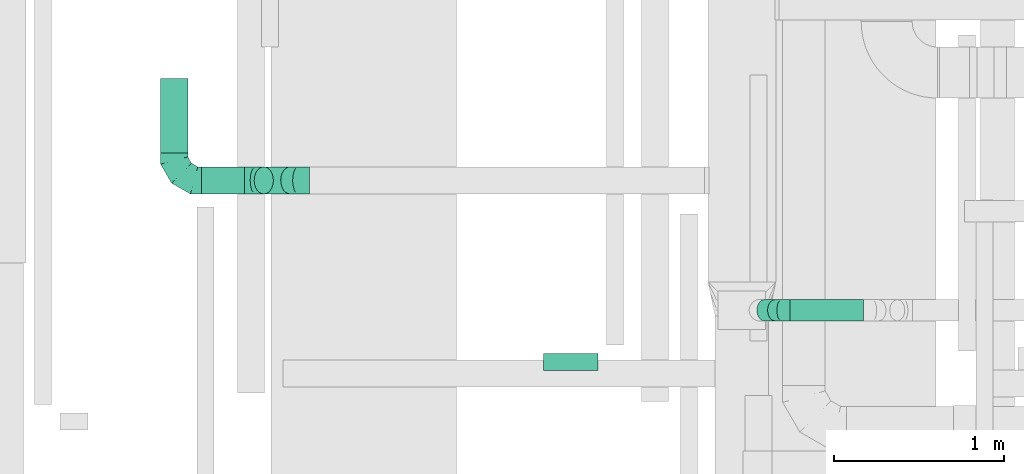
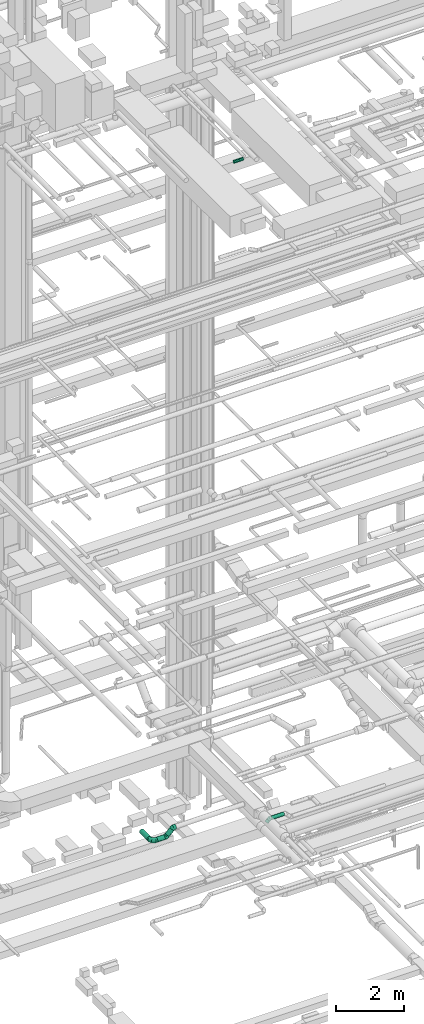
# One storey, part 120 of 337: 6 flow segments, 4 flow fittings.
"""IFC2X3 building model written with IfcOpenShell, lengths in millimetres."""

from ifc_helpers import new_model, entity, si_unit, converted_unit, derived_unit, direction, frame, origin, origin_2d_with_axis, place, context, subcontext, project, spatial, circle, extrude, faceted_brep, source, transform, mapped, material, type_object, type_shapes, element, save


model = new_model("IFC2X3")

# Units and contexts
model_context = context("Model", 3, precision=0.01, world=origin(), true_north=direction((6.12303176911189e-17, 1.0)))
body_context = subcontext(model_context, "Body", "Model", "MODEL_VIEW")
ifc_project = project(units=[si_unit("LENGTHUNIT", "METRE", prefix="MILLI"), si_unit("AREAUNIT", "SQUARE_METRE"), si_unit("VOLUMEUNIT", "CUBIC_METRE"), converted_unit("PLANEANGLEUNIT", "DEGREE", entity("IfcRatioMeasure", 0.0174532925199433), si_unit("PLANEANGLEUNIT", "RADIAN"), dimensions=[0, 0, 0, 0, 0, 0, 0]), si_unit("MASSUNIT", "GRAM", prefix="KILO"), derived_unit("MASSDENSITYUNIT", [(si_unit("MASSUNIT", "GRAM", prefix="KILO"), 1), (si_unit("LENGTHUNIT", "METRE"), -3)]), derived_unit("MOMENTOFINERTIAUNIT", [(si_unit("LENGTHUNIT", "METRE"), 4)]), si_unit("TIMEUNIT", "SECOND"), si_unit("FREQUENCYUNIT", "HERTZ"), si_unit("THERMODYNAMICTEMPERATUREUNIT", "DEGREE_CELSIUS"), derived_unit("THERMALTRANSMITTANCEUNIT", [(si_unit("MASSUNIT", "GRAM", prefix="KILO"), 1), (si_unit("THERMODYNAMICTEMPERATUREUNIT", "KELVIN"), -1), (si_unit("TIMEUNIT", "SECOND"), -3)]), derived_unit("VOLUMETRICFLOWRATEUNIT", [(si_unit("LENGTHUNIT", "METRE"), 3), (si_unit("TIMEUNIT", "SECOND"), -1)]), derived_unit("MASSFLOWRATEUNIT", [(si_unit("MASSUNIT", "GRAM", prefix="KILO"), 1), (si_unit("TIMEUNIT", "SECOND"), -1)]), derived_unit("ROTATIONALFREQUENCYUNIT", [(si_unit("TIMEUNIT", "SECOND"), -1)]), si_unit("ELECTRICCURRENTUNIT", "AMPERE"), si_unit("ELECTRICVOLTAGEUNIT", "VOLT"), si_unit("POWERUNIT", "WATT"), si_unit("FORCEUNIT", "NEWTON", prefix="KILO"), si_unit("ILLUMINANCEUNIT", "LUX"), si_unit("LUMINOUSFLUXUNIT", "LUMEN"), si_unit("LUMINOUSINTENSITYUNIT", "CANDELA"), derived_unit("USERDEFINED", [(si_unit("MASSUNIT", "GRAM", prefix="KILO"), -1), (si_unit("LENGTHUNIT", "METRE"), -2), (si_unit("TIMEUNIT", "SECOND"), 3), (si_unit("LUMINOUSFLUXUNIT", "LUMEN"), 1)]), derived_unit("LINEARVELOCITYUNIT", [(si_unit("LENGTHUNIT", "METRE"), 1), (si_unit("TIMEUNIT", "SECOND"), -1)]), si_unit("PRESSUREUNIT", "PASCAL"), derived_unit("USERDEFINED", [(si_unit("LENGTHUNIT", "METRE"), -2), (si_unit("MASSUNIT", "GRAM", prefix="KILO"), 1), (si_unit("TIMEUNIT", "SECOND"), -2)]), derived_unit("LINEARFORCEUNIT", [(si_unit("MASSUNIT", "GRAM", prefix="KILO"), 1), (si_unit("LENGTHUNIT", "METRE"), 1), (si_unit("TIMEUNIT", "SECOND"), -2), (si_unit("LENGTHUNIT", "METRE"), -1)]), derived_unit("PLANARFORCEUNIT", [(si_unit("MASSUNIT", "GRAM", prefix="KILO"), 1), (si_unit("LENGTHUNIT", "METRE"), 1), (si_unit("TIMEUNIT", "SECOND"), -2), (si_unit("LENGTHUNIT", "METRE"), -2)])], contexts=[model_context])

# Site, building, storey
site_placement = place(None, origin())
site = spatial("IfcSite", under=ifc_project, at=site_placement, CompositionType="ELEMENT")
building_placement = place(site_placement, origin())
building = spatial("IfcBuilding", under=site, at=building_placement, CompositionType="ELEMENT")
storey_placement = place(building_placement, origin())
storey = spatial("IfcBuildingStorey", under=building, at=storey_placement, CompositionType="ELEMENT", Elevation=0.0)

# Flow segments
duct_segment_type = type_object("IfcDuctSegmentType", PredefinedType="NOTDEFINED")
flow_segment_1_placement = place(storey_placement, frame((26754.46, 5894.29, 3188.7)))
element("IfcFlowSegment", 1, at=flow_segment_1_placement, inside=storey, type_object=duct_segment_type, context=body_context, shape_type="SweptSolid", body=[
    extrude(circle(Radius=80.0, at=origin_2d_with_axis()), frame((58.16, 81.6, 58.16), z_axis=(0.707106781186507, 0.0, 0.707106781186588), x_axis=(0.0, 1.0, 0.0)), (0.0, 0.0, 1.0), 221.005050633868),
])
flow_segment_2_placement = place(storey_placement, frame((26445.34, 5894.29, 3118.4)))
element("IfcFlowSegment", 2, at=flow_segment_2_placement, inside=storey, type_object=duct_segment_type, context=body_context, shape_type="SweptSolid", body=[
    extrude(circle(Radius=80.0, at=origin_2d_with_axis()), frame((0.0, 81.6, 81.6), z_axis=(1.0, 0.0, 0.0), x_axis=(0.0, 1.0, 0.0)), (0.0, 0.0, 1.0), 254.142135623723),
])
flow_segment_3_placement = place(storey_placement, frame((26203.75, 6135.89, 3118.4)))
element("IfcFlowSegment", 3, at=flow_segment_3_placement, inside=storey, type_object=duct_segment_type, context=body_context, shape_type="SweptSolid", body=[
    extrude(circle(Radius=80.0, at=origin_2d_with_axis()), frame((81.6, 0.0, 81.6), z_axis=(0.0, 1.0, 0.0), x_axis=(1.0, 0.0, 0.0)), (0.0, 0.0, 1.0), 440.000000000006),
])
flow_segment_4_placement = place(storey_placement, frame((28458.42, 4854.91, 27548.4)))
element("IfcFlowSegment", 4, at=flow_segment_4_placement, inside=storey, type_object=duct_segment_type, context=body_context, shape_type="SweptSolid", body=[
    extrude(circle(Radius=50.0, at=origin_2d_with_axis()), frame((0.0, 51.6, 51.6), z_axis=(1.0, 0.0, 0.0), x_axis=(0.0, 1.0, 0.0)), (0.0, 0.0, 1.0), 320.000000000018),
])
flow_segment_5_placement = place(storey_placement, frame((29909.87, 5147.75, 3169.75)))
element("IfcFlowSegment", 5, at=flow_segment_5_placement, inside=storey, type_object=duct_segment_type, context=body_context, shape_type="SweptSolid", body=[
    extrude(circle(Radius=62.5, at=origin_2d_with_axis()), frame((0.0, 64.1, 64.1), z_axis=(1.0, 0.0, 0.0), x_axis=(0.0, 1.0, 0.0)), (0.0, 0.0, 1.0), 431.314672620889),
])
flow_segment_6_placement = place(storey_placement, frame((29712.8, 5147.75, 3088.56)))
element("IfcFlowSegment", 6, at=flow_segment_6_placement, inside=storey, type_object=duct_segment_type, context=body_context, shape_type="SweptSolid", body=[
    extrude(circle(Radius=62.5, at=origin_2d_with_axis()), frame((45.79, 64.1, 45.79), z_axis=(0.707106781186542, 0.0, 0.707106781186553), x_axis=(0.0, 1.0, 0.0)), (0.0, 0.0, 1.0), 88.9339828220641),
])

# Flow fittings
ifc_material = material()
duct_fitting_type_1 = type_object("IfcDuctFittingType", PredefinedType="NOTDEFINED", material=ifc_material)
shared_shape_1 = source(origin(), body_context, "Body", "Brep", [
    faceted_brep([(-160.0, 0.0, -80.0), (-160.0, -20.71, -77.27), (-160.0, -40.0, -69.28), (-160.0, -56.57, -56.57), (-160.0, -69.28, -40.0), (-160.0, -77.27, -20.71), (-160.0, -80.0, 0.0), (-160.0, -77.27, 20.71), (-160.0, -69.28, 40.0), (-160.0, -56.57, 56.57), (-160.0, -40.0, 69.28), (-160.0, -20.71, 77.27), (-160.0, 0.0, 80.0), (-160.0, 20.71, 77.27), (-160.0, 40.0, 69.28), (-160.0, 56.57, 56.57), (-160.0, 69.28, 40.0), (-160.0, 77.27, 20.71), (-160.0, 80.0, 0.0), (-160.0, 77.27, -20.71), (-160.0, 69.28, -40.0), (-160.0, 56.57, -56.57), (-160.0, 40.0, -69.28), (-160.0, 20.71, -77.27), (-122.68, 20.71, 77.27), (-127.85, 40.0, 69.28), (-117.13, 0.0, 80.0), (-132.29, 56.57, 56.57), (-137.83, 77.27, 20.71), (-138.56, 80.0, 0.0), (-135.69, 69.28, 40.0), (-135.69, 69.28, -40.0), (-132.29, 56.57, -56.57), (-137.83, 77.27, -20.71), (-122.68, 20.71, -77.27), (-117.13, 0.0, -80.0), (-127.85, 40.0, -69.28), (-111.58, -20.71, -77.27), (-106.41, -40.0, -69.28), (-101.97, -56.57, -56.57), (-98.56, -69.28, -40.0), (-96.42, -77.27, -20.71), (-95.69, -80.0, 0.0), (-96.42, -77.27, 20.71), (-98.56, -69.28, 40.0), (-101.97, -56.57, 56.57), (-106.41, -40.0, 69.28), (-111.58, -20.71, 77.27), (-58.03, 58.03, 77.27), (-72.15, 72.15, 69.28), (-42.87, 42.87, 80.0), (-84.28, 84.28, 56.57), (-93.59, 93.59, 40.0), (-99.44, 99.44, 20.71), (-101.44, 101.44, 0.0), (-99.44, 99.44, -20.71), (-93.59, 93.59, -40.0), (-84.28, 84.28, -56.57), (-58.03, 58.03, -77.27), (-42.87, 42.87, -80.0), (-72.15, 72.15, -69.28), (-27.71, 27.71, -77.27), (-13.59, 13.59, -69.28), (-1.46, 1.46, -56.57), (7.85, -7.85, -40.0), (13.7, -13.7, -20.71), (15.69, -15.69, 0.0), (13.7, -13.7, 20.71), (7.85, -7.85, 40.0), (-1.46, 1.46, 56.57), (-13.59, 13.59, 69.28), (-27.71, 27.71, 77.27), (-20.71, 122.68, 77.27), (-40.0, 127.85, 69.28), (0.0, 117.13, 80.0), (-56.57, 132.29, 56.57), (-69.28, 135.69, 40.0), (-77.27, 137.83, 20.71), (-80.0, 138.56, 0.0), (-77.27, 137.83, -20.71), (-69.28, 135.69, -40.0), (-56.57, 132.29, -56.57), (-20.71, 122.68, -77.27), (0.0, 117.13, -80.0), (-40.0, 127.85, -69.28), (20.71, 111.58, -77.27), (40.0, 106.41, -69.28), (56.57, 101.97, -56.57), (69.28, 98.56, -40.0), (77.27, 96.42, -20.71), (80.0, 95.69, 0.0), (77.27, 96.42, 20.71), (69.28, 98.56, 40.0), (56.57, 101.97, 56.57), (40.0, 106.41, 69.28), (20.71, 111.58, 77.27), (-20.71, 160.0, -77.27), (-40.0, 160.0, -69.28), (-56.57, 160.0, -56.57), (-69.28, 160.0, -40.0), (-77.27, 160.0, -20.71), (-80.0, 160.0, 0.0), (-77.27, 160.0, 20.71), (-69.28, 160.0, 40.0), (-56.57, 160.0, 56.57), (-40.0, 160.0, 69.28), (-20.71, 160.0, 77.27), (0.0, 160.0, 80.0), (20.71, 160.0, 77.27), (40.0, 160.0, 69.28), (56.57, 160.0, 56.57), (69.28, 160.0, 40.0), (77.27, 160.0, 20.71), (80.0, 160.0, 0.0), (77.27, 160.0, -20.71), (69.28, 160.0, -40.0), (56.57, 160.0, -56.57), (40.0, 160.0, -69.28), (20.71, 160.0, -77.27), (0.0, 160.0, -80.0)], [[[0, 1, 2, 3, 4, 5, 6, 7, 8, 9, 10, 11, 12, 13, 14, 15, 16, 17, 18, 19, 20, 21, 22, 23]], [[24, 25, 14, 13]], [[26, 24, 13, 12]], [[14, 25, 27, 15]], [[28, 29, 18, 17]], [[30, 28, 17, 16]], [[15, 27, 30, 16]], [[20, 31, 32, 21]], [[33, 31, 20, 19]], [[18, 29, 33, 19]], [[34, 35, 0, 23]], [[36, 34, 23, 22]], [[32, 36, 22, 21]], [[1, 0, 35, 37]], [[2, 1, 37, 38]], [[3, 2, 38, 39]], [[5, 4, 40, 41]], [[6, 5, 41, 42]], [[39, 40, 4, 3]], [[6, 42, 43, 7]], [[7, 43, 44, 8]], [[8, 44, 45, 9]], [[9, 45, 46, 10]], [[10, 46, 47, 11]], [[26, 12, 11, 47]], [[48, 49, 25, 24]], [[50, 48, 24, 26]], [[27, 25, 49, 51]], [[52, 53, 28, 30]], [[51, 52, 30, 27]], [[29, 28, 53, 54]], [[55, 56, 31, 33]], [[54, 55, 33, 29]], [[32, 31, 56, 57]], [[58, 59, 35, 34]], [[60, 58, 34, 36]], [[57, 60, 36, 32]], [[37, 35, 59, 61]], [[38, 37, 61, 62]], [[39, 38, 62, 63]], [[41, 40, 64, 65]], [[42, 41, 65, 66]], [[63, 64, 40, 39]], [[43, 42, 66, 67]], [[44, 43, 67, 68]], [[68, 69, 45, 44]], [[46, 45, 69, 70]], [[47, 46, 70, 71]], [[26, 47, 71, 50]], [[72, 73, 49, 48]], [[74, 72, 48, 50]], [[51, 49, 73, 75]], [[76, 77, 53, 52]], [[75, 76, 52, 51]], [[54, 53, 77, 78]], [[79, 80, 56, 55]], [[78, 79, 55, 54]], [[57, 56, 80, 81]], [[82, 83, 59, 58]], [[84, 82, 58, 60]], [[81, 84, 60, 57]], [[61, 59, 83, 85]], [[62, 61, 85, 86]], [[63, 62, 86, 87]], [[65, 64, 88, 89]], [[66, 65, 89, 90]], [[87, 88, 64, 63]], [[67, 66, 90, 91]], [[68, 67, 91, 92]], [[92, 93, 69, 68]], [[70, 69, 93, 94]], [[71, 70, 94, 95]], [[50, 71, 95, 74]], [[96, 97, 98, 99, 100, 101, 102, 103, 104, 105, 106, 107, 108, 109, 110, 111, 112, 113, 114, 115, 116, 117, 118, 119]], [[72, 74, 107, 106]], [[73, 72, 106, 105]], [[75, 73, 105, 104]], [[77, 76, 103, 102]], [[78, 77, 102, 101]], [[75, 104, 103, 76]], [[78, 101, 100, 79]], [[79, 100, 99, 80]], [[80, 99, 98, 81]], [[84, 97, 96, 82]], [[82, 96, 119, 83]], [[84, 81, 98, 97]], [[118, 117, 86, 85]], [[119, 118, 85, 83]], [[116, 87, 86, 117]], [[88, 115, 114, 89]], [[89, 114, 113, 90]], [[115, 88, 87, 116]], [[112, 111, 92, 91]], [[113, 112, 91, 90]], [[111, 110, 93, 92]], [[95, 94, 109, 108]], [[74, 95, 108, 107]], [[110, 109, 94, 93]]]),
])
type_shapes(duct_fitting_type_1, [shared_shape_1])
flow_fitting_1_placement = place(storey_placement, frame((26285.34, 5975.89, 3200.0), z_axis=(0.0, 0.0, 1.0), x_axis=(0.0, -1.0, 0.0)))
element("IfcFlowFitting", 7, at=flow_fitting_1_placement, inside=storey, type_object=duct_fitting_type_1, material=ifc_material, context=body_context, shape_type="MappedRepresentation", body=[
    mapped(shared_shape_1, transform((0.0, 0.0, 0.0), scale=1.0)),
])
duct_fitting_type_2 = type_object("IfcDuctFittingType", PredefinedType="NOTDEFINED", material=ifc_material)
shared_shape_2 = source(origin(), body_context, "Body", "Brep", [
    faceted_brep([(-51.78, 0.0, -62.5), (-51.78, -16.18, -60.37), (-51.78, -31.25, -54.13), (-51.78, -44.19, -44.19), (-51.78, -54.13, -31.25), (-51.78, -60.37, -16.18), (-51.78, -62.5, 0.0), (-51.78, -60.37, 16.18), (-51.78, -54.13, 31.25), (-51.78, -44.19, 44.19), (-51.78, -31.25, 54.13), (-51.78, -16.18, 60.37), (-51.78, 0.0, 62.5), (-51.78, 16.18, 60.37), (-51.78, 31.25, 54.13), (-51.78, 44.19, 44.19), (-51.78, 54.13, 31.25), (-51.78, 60.37, 16.18), (-51.78, 62.5, 0.0), (-51.78, 60.37, -16.18), (-51.78, 54.13, -31.25), (-51.78, 44.19, -44.19), (-51.78, 31.25, -54.13), (-51.78, 16.18, -60.37), (-6.7, 16.18, 60.37), (-12.94, 31.25, 54.13), (0.0, 0.0, 62.5), (-18.31, 44.19, 44.19), (-22.42, 54.13, 31.25), (-25.01, 60.37, 16.18), (-25.89, 62.5, 0.0), (-25.01, 60.37, -16.18), (-22.42, 54.13, -31.25), (-18.31, 44.19, -44.19), (-6.7, 16.18, -60.37), (0.0, 0.0, -62.5), (-12.94, 31.25, -54.13), (6.7, -16.18, -60.37), (12.94, -31.25, -54.13), (18.31, -44.19, -44.19), (22.42, -54.13, -31.25), (25.01, -60.37, -16.18), (25.89, -62.5, 0.0), (25.01, -60.37, 16.18), (22.42, -54.13, 31.25), (18.31, -44.19, 44.19), (12.94, -31.25, 54.13), (6.7, -16.18, 60.37), (25.17, 48.05, 60.37), (14.51, 58.71, 54.13), (36.61, 36.61, 62.5), (5.36, 67.86, 44.19), (-1.66, 74.88, 31.25), (-6.08, 79.3, 16.18), (-7.58, 80.81, 0.0), (-6.08, 79.3, -16.18), (-1.66, 74.88, -31.25), (5.36, 67.86, -44.19), (14.51, 58.71, -54.13), (25.17, 48.05, -60.37), (36.61, 36.61, -62.5), (48.05, 25.17, -60.37), (58.71, 14.51, -54.13), (67.86, 5.36, -44.19), (74.88, -1.66, -31.25), (79.3, -6.08, -16.18), (80.81, -7.58, 0.0), (79.3, -6.08, 16.18), (74.88, -1.66, 31.25), (67.86, 5.36, 44.19), (58.71, 14.51, 54.13), (48.05, 25.17, 60.37)], [[[0, 1, 2, 3, 4, 5, 6, 7, 8, 9, 10, 11, 12, 13, 14, 15, 16, 17, 18, 19, 20, 21, 22, 23]], [[24, 25, 14, 13]], [[26, 24, 13, 12]], [[27, 15, 14, 25]], [[28, 29, 17, 16]], [[28, 16, 15, 27]], [[30, 18, 17, 29]], [[31, 32, 20, 19]], [[30, 31, 19, 18]], [[21, 20, 32, 33]], [[34, 35, 0, 23]], [[36, 34, 23, 22]], [[33, 36, 22, 21]], [[1, 0, 35, 37]], [[2, 1, 37, 38]], [[38, 39, 3, 2]], [[5, 4, 40, 41]], [[6, 5, 41, 42]], [[39, 40, 4, 3]], [[6, 42, 43, 7]], [[7, 43, 44, 8]], [[8, 44, 45, 9]], [[9, 45, 46, 10]], [[10, 46, 47, 11]], [[26, 12, 11, 47]], [[48, 49, 25, 24]], [[50, 48, 24, 26]], [[27, 25, 49, 51]], [[29, 28, 52, 53]], [[30, 29, 53, 54]], [[51, 52, 28, 27]], [[30, 54, 55, 31]], [[31, 55, 56, 32]], [[57, 33, 32, 56]], [[36, 58, 59, 34]], [[34, 59, 60, 35]], [[58, 36, 33, 57]], [[35, 60, 61, 37]], [[37, 61, 62, 38]], [[63, 39, 38, 62]], [[40, 64, 65, 41]], [[41, 65, 66, 42]], [[64, 40, 39, 63]], [[43, 42, 66, 67]], [[44, 43, 67, 68]], [[68, 69, 45, 44]], [[47, 46, 70, 71]], [[26, 47, 71, 50]], [[69, 70, 46, 45]], [[59, 58, 57, 56, 55, 54, 53, 52, 51, 49, 48, 50, 71, 70, 69, 68, 67, 66, 65, 64, 63, 62, 61, 60]]]),
])
type_shapes(duct_fitting_type_2, [shared_shape_2])
flow_fitting_2_placement = place(storey_placement, frame((29858.09, 5211.84, 3233.85), z_axis=(0.0, -1.0, 0.0), x_axis=(-1.0, 0.0, 0.0)))
element("IfcFlowFitting", 8, at=flow_fitting_2_placement, inside=storey, type_object=duct_fitting_type_2, material=ifc_material, context=body_context, shape_type="MappedRepresentation", body=[
    mapped(shared_shape_2, transform((0.0, 0.0, 0.0), scale=1.0)),
])
duct_fitting_type_3 = type_object("IfcDuctFittingType", PredefinedType="NOTDEFINED", material=ifc_material)
shared_shape_3 = source(origin(), body_context, "Body", "Brep", [
    faceted_brep([(-66.27, 0.0, -80.0), (-66.27, -20.71, -77.27), (-66.27, -40.0, -69.28), (-66.27, -56.57, -56.57), (-66.27, -69.28, -40.0), (-66.27, -77.27, -20.71), (-66.27, -80.0, 0.0), (-66.27, -77.27, 20.71), (-66.27, -69.28, 40.0), (-66.27, -56.57, 56.57), (-66.27, -40.0, 69.28), (-66.27, -20.71, 77.27), (-66.27, 0.0, 80.0), (-66.27, 20.71, 77.27), (-66.27, 40.0, 69.28), (-66.27, 56.57, 56.57), (-66.27, 69.28, 40.0), (-66.27, 77.27, 20.71), (-66.27, 80.0, 0.0), (-66.27, 77.27, -20.71), (-66.27, 69.28, -40.0), (-66.27, 56.57, -56.57), (-66.27, 40.0, -69.28), (-66.27, 20.71, -77.27), (-8.58, 20.71, 77.27), (-16.57, 40.0, 69.28), (0.0, 0.0, 80.0), (-23.43, 56.57, 56.57), (-28.7, 69.28, 40.0), (-32.01, 77.27, 20.71), (-33.14, 80.0, 0.0), (-32.01, 77.27, -20.71), (-28.7, 69.28, -40.0), (-23.43, 56.57, -56.57), (-8.58, 20.71, -77.27), (0.0, 0.0, -80.0), (-16.57, 40.0, -69.28), (8.58, -20.71, -77.27), (16.57, -40.0, -69.28), (23.43, -56.57, -56.57), (28.7, -69.28, -40.0), (32.01, -77.27, -20.71), (33.14, -80.0, 0.0), (32.01, -77.27, 20.71), (28.7, -69.28, 40.0), (23.43, -56.57, 56.57), (16.57, -40.0, 69.28), (8.58, -20.71, 77.27), (46.86, 46.86, 80.0), (32.22, 61.5, 77.27), (18.58, 75.15, 69.28), (6.86, 86.86, 56.57), (-2.13, 95.85, 40.0), (-7.78, 101.5, 20.71), (-9.71, 103.43, 0.0), (-7.78, 101.5, -20.71), (-2.13, 95.85, -40.0), (6.86, 86.86, -56.57), (18.58, 75.15, -69.28), (32.22, 61.5, -77.27), (46.86, 46.86, -80.0), (61.5, 32.22, -77.27), (75.15, 18.58, -69.28), (86.86, 6.86, -56.57), (95.85, -2.13, -40.0), (101.5, -7.78, -20.71), (103.43, -9.71, 0.0), (101.5, -7.78, 20.71), (95.85, -2.13, 40.0), (86.86, 6.86, 56.57), (75.15, 18.58, 69.28), (61.5, 32.22, 77.27)], [[[0, 1, 2, 3, 4, 5, 6, 7, 8, 9, 10, 11, 12, 13, 14, 15, 16, 17, 18, 19, 20, 21, 22, 23]], [[24, 25, 14, 13]], [[26, 24, 13, 12]], [[14, 25, 27, 15]], [[28, 29, 17, 16]], [[28, 16, 15, 27]], [[30, 18, 17, 29]], [[31, 32, 20, 19]], [[30, 31, 19, 18]], [[32, 33, 21, 20]], [[34, 35, 0, 23]], [[36, 34, 23, 22]], [[33, 36, 22, 21]], [[1, 0, 35, 37]], [[2, 1, 37, 38]], [[38, 39, 3, 2]], [[5, 4, 40, 41]], [[6, 5, 41, 42]], [[39, 40, 4, 3]], [[6, 42, 43, 7]], [[7, 43, 44, 8]], [[8, 44, 45, 9]], [[9, 45, 46, 10]], [[10, 46, 47, 11]], [[26, 12, 11, 47]], [[24, 26, 48, 49]], [[25, 24, 49, 50]], [[27, 25, 50, 51]], [[29, 28, 52, 53]], [[30, 29, 53, 54]], [[51, 52, 28, 27]], [[30, 54, 55, 31]], [[31, 55, 56, 32]], [[57, 33, 32, 56]], [[36, 58, 59, 34]], [[34, 59, 60, 35]], [[58, 36, 33, 57]], [[35, 60, 61, 37]], [[37, 61, 62, 38]], [[63, 39, 38, 62]], [[40, 64, 65, 41]], [[41, 65, 66, 42]], [[64, 40, 39, 63]], [[43, 42, 66, 67]], [[44, 43, 67, 68]], [[68, 69, 45, 44]], [[47, 46, 70, 71]], [[26, 47, 71, 48]], [[69, 70, 46, 45]], [[59, 58, 57, 56, 55, 54, 53, 52, 51, 50, 49, 48, 71, 70, 69, 68, 67, 66, 65, 64, 63, 62, 61, 60]]]),
])
type_shapes(duct_fitting_type_3, [shared_shape_3])
for number, where, z_axis, x_axis in (
    (9, (27015.76, 5975.89, 3450.0), (0.0, -1.0, 0.0), (-1.0, 0.0, 0.0)),
    (10, (26765.76, 5975.89, 3200.0), (0.0, 1.0, 0.0), (-0.707106781186514, 0.0, -0.707106781186581)),
):
    element("IfcFlowFitting", number, at=place(storey_placement, frame(where, z_axis=z_axis, x_axis=x_axis)), inside=storey, type_object=duct_fitting_type_3, material=ifc_material, context=body_context, shape_type="MappedRepresentation", body=[
        mapped(shared_shape_3, transform((0.0, 0.0, 0.0), scale=1.0)),
    ])

save(model, "model.ifc")
